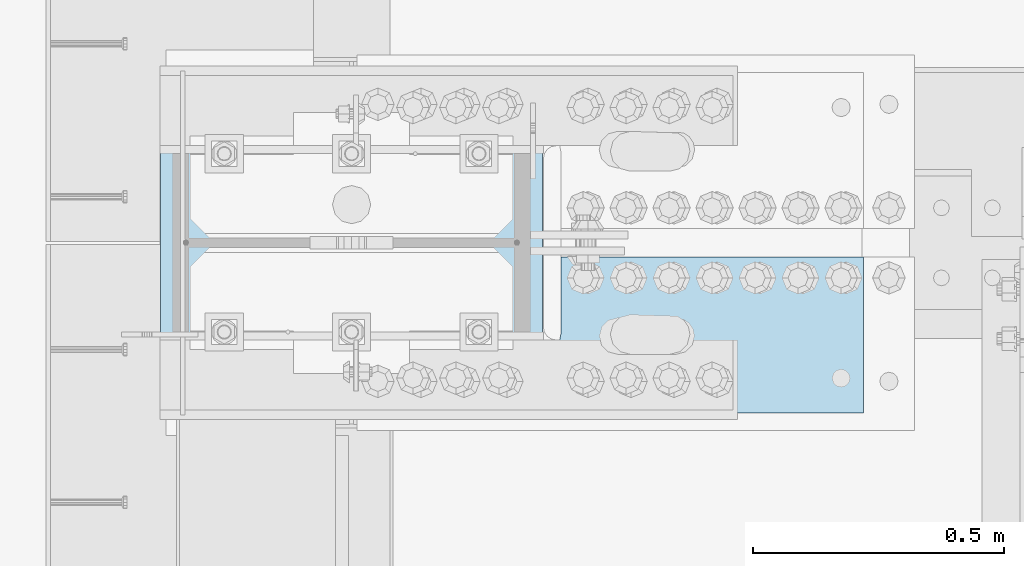
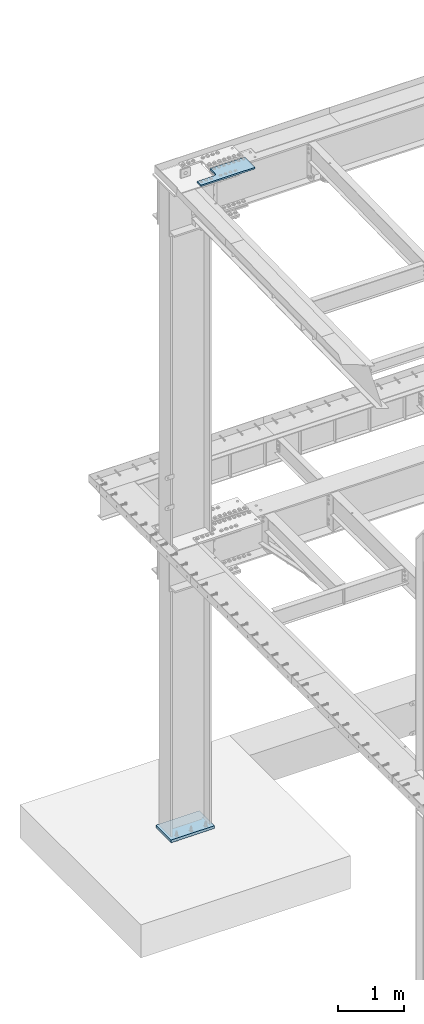
# One storey, part 1596 of 1763: 2 plates, 2 elements without a shape of their own.
"""IFC2X3 building model written with IfcOpenShell, lengths in millimetres."""

from ifc_helpers import new_model, si_unit, frame, origin_with_axes, place, context, subcontext, project, spatial, faceted_brep, material, type_object, element, aggregate, save


model = new_model("IFC2X3")

# Units and contexts
model_context = context("Model", 3, precision=1e-05, world=origin_with_axes())
body_context = subcontext(model_context, "Body", "Model", "MODEL_VIEW")
ifc_project = project(units=[si_unit("LENGTHUNIT", "METRE", prefix="MILLI"), si_unit("AREAUNIT", "SQUARE_METRE"), si_unit("VOLUMEUNIT", "CUBIC_METRE"), si_unit("MASSUNIT", "GRAM", prefix="KILO"), si_unit("TIMEUNIT", "SECOND"), si_unit("PLANEANGLEUNIT", "RADIAN"), si_unit("SOLIDANGLEUNIT", "STERADIAN"), si_unit("THERMODYNAMICTEMPERATUREUNIT", "DEGREE_CELSIUS"), si_unit("LUMINOUSINTENSITYUNIT", "LUMEN")], contexts=[model_context])

# Site, building, storey
site_placement = place(None, origin_with_axes())
site = spatial("IfcSite", under=ifc_project, at=site_placement, CompositionType="ELEMENT")
building_placement = place(site_placement, origin_with_axes())
building = spatial("IfcBuilding", under=site, at=building_placement, Name="Undefined", CompositionType="ELEMENT")
storey_placement = place(building_placement, origin_with_axes())
storey = spatial("IfcBuildingStorey", under=building, at=storey_placement, Name="Undefined", CompositionType="ELEMENT", Elevation=0.0)

# Assembly, plate
assembly_1_placement = place(storey_placement, origin_with_axes())
assembly_1 = element("IfcElementAssembly", 1, at=assembly_1_placement, inside=storey, Name="TOP PLATE", AssemblyPlace="NOTDEFINED", PredefinedType="RIGID_FRAME")
ifc_material_1 = material(Name="STEEL/A572-50")
plate_type_1 = type_object("IfcPlateType", PredefinedType="NOTDEFINED")
plate_1_placement = place(assembly_1_placement, frame((-86354.6747736984, 52092.2250002128, 11761.7874917654), z_axis=(0.0, -1.0, 0.0), x_axis=(-1.0, 0.0, 0.0)))
plate_1 = element("IfcPlate", 2, at=plate_1_placement, type_object=plate_type_1, material=ifc_material_1, Name="TOP PLATE", context=body_context, shape_type="Brep", body=[
    faceted_brep([(0.0, -14.2875000000058, 0.0), (0.0, -14.2875000000004, 311.149993896484), (0.0, 14.2875000000004, 311.149993896484), (0.0, 14.2875000000058, 0.0), (939.799987792969, -14.2875000000004, 311.149993896484), (939.799987792969, 14.2875000000004, 311.149993896484), (939.799987792969, -14.2875000000004, 193.675003051758), (939.799987792969, 14.2875000000004, 193.675003051758), (644.525001525879, -14.2875000000004, 193.675003051758), (644.525001525879, 14.2875000000004, 193.675003051758), (628.729742271084, -14.2875000000004, 190.533130640011), (628.729742271084, 14.2875000000004, 190.533130640011), (615.339168053448, -14.2875000000004, 181.58583499831), (615.339168053448, 14.2875000000004, 181.58583499831), (606.391872411747, -14.2875000000004, 168.195260780674), (606.391872411747, 14.2875000000004, 168.195260780674), (603.25, -14.2875000000004, 152.400001525879), (603.25, 14.2875000000004, 152.400001525879), (603.25, -14.2875000000004, 0.0), (603.25, 14.2875000000004, 0.0)], [[[0, 1, 2, 3]], [[1, 4, 5, 2]], [[4, 6, 7, 5]], [[6, 8, 9, 7]], [[8, 10, 11, 9]], [[10, 12, 13, 11]], [[12, 14, 15, 13]], [[14, 16, 17, 15]], [[16, 18, 19, 17]], [[18, 0, 3, 19]], [[5, 7, 9, 11, 13, 15, 17, 19, 3, 2]], [[18, 16, 14, 12, 10, 8, 6, 4, 1, 0]]]),
])
aggregate(assembly_1, [plate_1])

assembly_2_placement = place(storey_placement, origin_with_axes())
assembly_2 = element("IfcElementAssembly", 3, at=assembly_2_placement, inside=storey, Name="COLUMN", AssemblyPlace="NOTDEFINED", PredefinedType="RIGID_FRAME")
ifc_material_2 = material(Name="STEEL/A36")
plate_type_2 = type_object("IfcPlateType", PredefinedType="NOTDEFINED")
plate_2_placement = place(assembly_2_placement, frame((-87756.4372736983, 51892.2, -241.300000000016), z_axis=(0.0, 1.0, 0.0), x_axis=(1.0, 0.0, 0.0)))
plate_2 = element("IfcPlate", 4, at=plate_2_placement, type_object=plate_type_2, material=ifc_material_2, Name="PLATE", context=body_context, shape_type="Brep", body=[
    faceted_brep([(0.0, -25.4000000000015, 0.0), (0.0, -25.4, 457.200012207031), (0.0, 25.4, 457.200012207031), (0.0, 25.4000000000015, 0.0), (762.0, -25.4, 457.200012207031), (762.0, 25.4, 457.200012207031), (762.0, -25.4, 0.0), (762.0, 25.4, 0.0)], [[[0, 1, 2, 3]], [[1, 4, 5, 2]], [[4, 6, 7, 5]], [[6, 0, 3, 7]], [[5, 7, 3, 2]], [[6, 4, 1, 0]]]),
])
aggregate(assembly_2, [plate_2])

save(model, "model.ifc")
